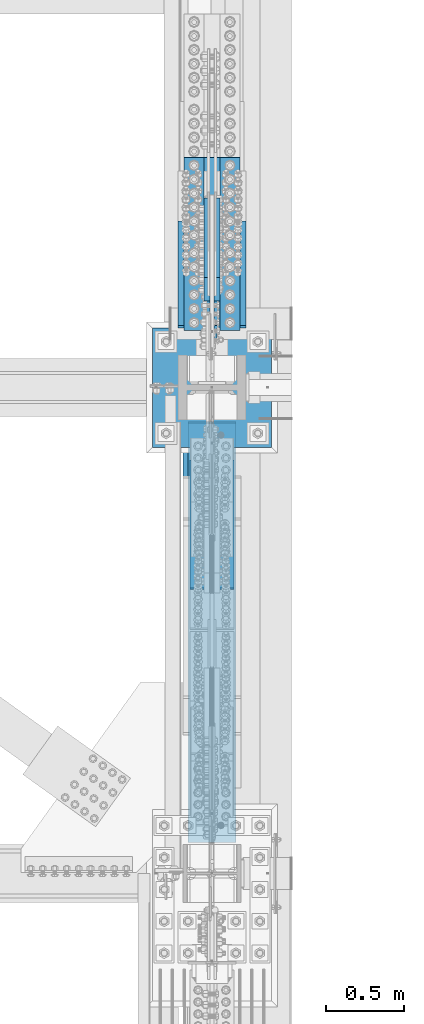
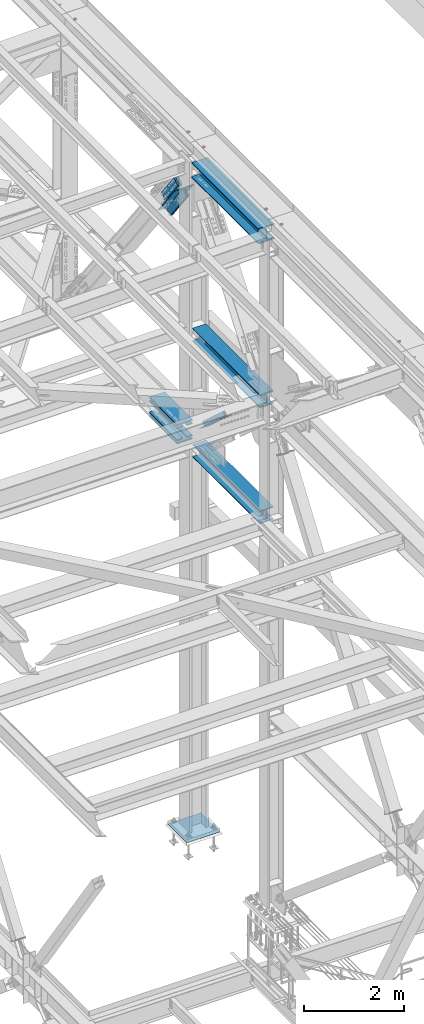
# One storey, part 1957 of 3843: 10 beams, 6 members, 7 elements without a shape of their own.
"""IFC2X3 building model written with IfcOpenShell, lengths in millimetres."""

from ifc_helpers import new_model, si_unit, frame, origin_with_axes, place, context, subcontext, project, spatial, faceted_brep, material, type_object, element, aggregate, save


model = new_model("IFC2X3")

# Units and contexts
model_context = context("Model", 3, precision=1e-05, world=origin_with_axes())
body_context = subcontext(model_context, "Body", "Model", "MODEL_VIEW")
ifc_project = project(units=[si_unit("LENGTHUNIT", "METRE", prefix="MILLI"), si_unit("AREAUNIT", "SQUARE_METRE"), si_unit("VOLUMEUNIT", "CUBIC_METRE"), si_unit("MASSUNIT", "GRAM", prefix="KILO"), si_unit("TIMEUNIT", "SECOND"), si_unit("PLANEANGLEUNIT", "RADIAN"), si_unit("SOLIDANGLEUNIT", "STERADIAN"), si_unit("THERMODYNAMICTEMPERATUREUNIT", "DEGREE_CELSIUS"), si_unit("LUMINOUSINTENSITYUNIT", "LUMEN")], contexts=[model_context])

# Site, building, storey
site_placement = place(None, origin_with_axes())
site = spatial("IfcSite", under=ifc_project, at=site_placement, CompositionType="ELEMENT")
building_placement = place(site_placement, origin_with_axes())
building = spatial("IfcBuilding", under=site, at=building_placement, Name="Undefined", CompositionType="ELEMENT")
storey_placement = place(building_placement, origin_with_axes())
storey = spatial("IfcBuildingStorey", under=building, at=storey_placement, Name="Undefined", CompositionType="ELEMENT", Elevation=0.0)

# Assembly, beams
assembly_1_placement = place(storey_placement, origin_with_axes())
assembly_1 = element("IfcElementAssembly", 1, at=assembly_1_placement, inside=storey, Name="COLUMN", AssemblyPlace="NOTDEFINED", PredefinedType="RIGID_FRAME")
ifc_material_1 = material(Name="STEEL/A572-50")
beam_type_1 = type_object("IfcBeamType", PredefinedType="NOTDEFINED")
beam_1_placement = place(assembly_1_placement, frame((85763.1, 29078.3813100748, 39333.7241634409), z_axis=(-1.0, 0.0, 0.0), x_axis=(0.0, 0.999988026952938, 0.00489345999977453)))
beam_1 = element("IfcBeam", 2, at=beam_1_placement, type_object=beam_type_1, material=ifc_material_1, Name="PLATE", context=body_context, shape_type="Brep", body=[
    faceted_brep([(8.73114913702011e-11, 15.8750000000073, -63.5), (8.73114913702011e-11, 15.8750000000073, 63.5), (1104.89999997285, 15.8750000015862, 63.5), (1104.89999997285, 15.8750000015862, -63.5), (-1.01863406598568e-10, -15.8750000000146, 63.5), (1104.89999997268, -15.8749999984284, 63.5), (-1.01863406598568e-10, -15.8750000000146, -63.5), (1104.89999997268, -15.8749999984284, -63.5)], [[[0, 1, 2, 3]], [[1, 4, 5, 2]], [[4, 6, 7, 5]], [[6, 0, 3, 7]], [[5, 7, 3, 2]], [[6, 4, 1, 0]]]),
])
beam_2_placement = place(assembly_1_placement, frame((85763.1, 29076.9677179651, 39622.5944270495), z_axis=(-1.0, 0.0, 0.0), x_axis=(0.0, 0.999988026952938, 0.00489345999977453)))
beam_2 = element("IfcBeam", 3, at=beam_2_placement, type_object=beam_type_1, material=ifc_material_1, Name="PLATE", context=body_context, shape_type="Brep", body=[
    faceted_brep([(8.73114913702011e-11, 15.8750000000073, -63.5), (8.73114913702011e-11, 15.8750000000073, 63.5), (1104.89999997285, 15.8750000015862, 63.5), (1104.89999997285, 15.8750000015862, -63.5), (-1.01863406598568e-10, -15.8750000000146, 63.5), (1104.89999997268, -15.8749999984284, 63.5), (-1.01863406598568e-10, -15.8750000000146, -63.5), (1104.89999997268, -15.8749999984284, -63.5)], [[[0, 1, 2, 3]], [[1, 4, 5, 2]], [[4, 6, 7, 5]], [[6, 0, 3, 7]], [[5, 7, 3, 2]], [[6, 4, 1, 0]]]),
])
beam_3_placement = place(assembly_1_placement, frame((85534.5, 29078.3813100748, 39333.7241634409), z_axis=(-1.0, 0.0, 0.0), x_axis=(0.0, 0.999988026952938, 0.00489345999977453)))
beam_3 = element("IfcBeam", 4, at=beam_3_placement, type_object=beam_type_1, material=ifc_material_1, Name="PLATE", context=body_context, shape_type="Brep", body=[
    faceted_brep([(8.73114913702011e-11, 15.8750000000073, -63.5), (8.73114913702011e-11, 15.8750000000073, 63.5), (1104.89999997285, 15.8750000015862, 63.5), (1104.89999997285, 15.8750000015862, -63.5), (-1.01863406598568e-10, -15.8750000000146, 63.5), (1104.89999997268, -15.8749999984284, 63.5), (-1.01863406598568e-10, -15.8750000000146, -63.5), (1104.89999997268, -15.8749999984284, -63.5)], [[[0, 1, 2, 3]], [[1, 4, 5, 2]], [[4, 6, 7, 5]], [[6, 0, 3, 7]], [[5, 7, 3, 2]], [[6, 4, 1, 0]]]),
])
beam_4_placement = place(assembly_1_placement, frame((85534.5, 29076.9677179651, 39622.5944270495), z_axis=(-1.0, 0.0, 0.0), x_axis=(0.0, 0.999988026952938, 0.00489345999977453)))
beam_4 = element("IfcBeam", 5, at=beam_4_placement, type_object=beam_type_1, material=ifc_material_1, Name="PLATE", context=body_context, shape_type="Brep", body=[
    faceted_brep([(8.73114913702011e-11, 15.8750000000073, -63.5), (8.73114913702011e-11, 15.8750000000073, 63.5), (1104.89999997285, 15.8750000015862, 63.5), (1104.89999997285, 15.8750000015862, -63.5), (-1.01863406598568e-10, -15.8750000000146, 63.5), (1104.89999997268, -15.8749999984284, 63.5), (-1.01863406598568e-10, -15.8750000000146, -63.5), (1104.89999997268, -15.8749999984284, -63.5)], [[[0, 1, 2, 3]], [[1, 4, 5, 2]], [[4, 6, 7, 5]], [[6, 0, 3, 7]], [[5, 7, 3, 2]], [[6, 4, 1, 0]]]),
])
beam_type_2 = type_object("IfcBeamType", PredefinedType="NOTDEFINED")
beam_5_placement = place(assembly_1_placement, frame((85648.8, 30183.6580881861, 39259.7461953867), z_axis=(-1.0, 0.0, 0.0), x_axis=(0.0, -0.999988026952938, -0.00489345999977453)))
beam_5 = element("IfcBeam", 6, at=beam_5_placement, type_object=beam_type_2, material=ifc_material_1, Name="PLATE", context=body_context, shape_type="Brep", body=[
    faceted_brep([(1.45519152283669e-11, 15.8750000000218, -177.800000000003), (1.45519152283669e-11, 15.8750000000218, 177.800000000003), (1104.89999996551, 15.8749999977663, 177.800000000003), (1104.89999996551, 15.8749999977663, -177.800000000003), (-4.36557456851006e-11, -15.8750000000146, 177.800000000003), (1104.89999996545, -15.8750000022774, 177.800000000003), (-4.36557456851006e-11, -15.8750000000146, -177.800000000003), (1104.89999996545, -15.8750000022774, -177.800000000003)], [[[0, 1, 2, 3]], [[1, 4, 5, 2]], [[4, 6, 7, 5]], [[6, 0, 3, 7]], [[5, 7, 3, 2]], [[6, 4, 1, 0]]]),
])
beam_6_placement = place(assembly_1_placement, frame((85648.8, 30181.4652221624, 39707.548624072), z_axis=(-1.0, 0.0, 0.0), x_axis=(0.0, -0.999988026952938, -0.00489345999977453)))
beam_6 = element("IfcBeam", 7, at=beam_6_placement, type_object=beam_type_2, material=ifc_material_1, Name="PLATE", context=body_context, shape_type="Brep", body=[
    faceted_brep([(1.45519152283669e-11, 15.8750000000218, -177.800000000003), (1.45519152283669e-11, 15.8750000000218, 177.800000000003), (1104.89999996551, 15.8749999977663, 177.800000000003), (1104.89999996551, 15.8749999977663, -177.800000000003), (-4.36557456851006e-11, -15.8750000000146, 177.800000000003), (1104.89999996545, -15.8750000022774, 177.800000000003), (-4.36557456851006e-11, -15.8750000000146, -177.800000000003), (1104.89999996545, -15.8750000022774, -177.800000000003)], [[[0, 1, 2, 3]], [[1, 4, 5, 2]], [[4, 6, 7, 5]], [[6, 0, 3, 7]], [[5, 7, 3, 2]], [[6, 4, 1, 0]]]),
])
aggregate(assembly_1, [beam_1, beam_2, beam_3, beam_4, beam_5, beam_6])

# Assembly, members
assembly_2_placement = place(storey_placement, origin_with_axes())
assembly_2 = element("IfcElementAssembly", 8, at=assembly_2_placement, inside=storey, Name="V. BRACE", AssemblyPlace="NOTDEFINED", PredefinedType="RIGID_FRAME")
member_type_1 = type_object("IfcMemberType", PredefinedType="NOTDEFINED")
member_1_placement = place(assembly_2_placement, frame((85680.55, 29341.3828673622, 45424.3500689701), z_axis=(0.0, 0.796057772587748, 0.60522063968658), x_axis=(0.0, 0.605220639686578, -0.79605777258775)))
member_1 = element("IfcMember", 9, at=member_1_placement, type_object=member_type_1, material=ifc_material_1, Name="PLATE", context=body_context, shape_type="Brep", body=[
    faceted_brep([(1.16415321826935e-10, 19.0500000000029, -95.2500000001601), (-1.16415321826935e-10, 19.0500000000029, 95.2500000001601), (838.200000012905, 19.0500000000029, 95.250000001266), (838.200000013152, 19.0500000000029, -95.249999999076), (-1.16415321826935e-10, -19.0500000000029, 95.2500000001601), (838.200000012905, -19.0500000000029, 95.250000001266), (1.16415321826935e-10, -19.0500000000029, -95.2500000001601), (838.200000013152, -19.0500000000029, -95.249999999076)], [[[0, 1, 2, 3]], [[1, 4, 5, 2]], [[4, 6, 7, 5]], [[6, 0, 3, 7]], [[5, 7, 3, 2]], [[6, 4, 1, 0]]]),
])
member_2_placement = place(assembly_2_placement, frame((85617.05, 29341.3828673622, 45424.3500689701), z_axis=(0.0, 0.796057772587748, 0.60522063968658), x_axis=(0.0, 0.605220639686578, -0.79605777258775)))
member_2 = element("IfcMember", 10, at=member_2_placement, type_object=member_type_1, material=ifc_material_1, Name="PLATE", context=body_context, shape_type="Brep", body=[
    faceted_brep([(1.16415321826935e-10, 19.0500000000029, -95.2500000001601), (-1.16415321826935e-10, 19.0500000000029, 95.2500000001601), (838.200000012905, 19.0500000000029, 95.250000001266), (838.200000013152, 19.0500000000029, -95.249999999076), (-1.16415321826935e-10, -19.0500000000029, 95.2500000001601), (838.200000012905, -19.0500000000029, 95.250000001266), (1.16415321826935e-10, -19.0500000000029, -95.2500000001601), (838.200000013152, -19.0500000000029, -95.249999999076)], [[[0, 1, 2, 3]], [[1, 4, 5, 2]], [[4, 6, 7, 5]], [[6, 0, 3, 7]], [[5, 7, 3, 2]], [[6, 4, 1, 0]]]),
])
member_type_2 = type_object("IfcMemberType", Name="L8X8X3/4", PredefinedType="NOTDEFINED")
member_3_placement = place(assembly_2_placement, frame((85763.1, 29696.8563105987, 44474.1546618168), z_axis=(0.0, -0.796057916025909, -0.605220451019698), x_axis=(0.0, -0.605220451019698, 0.796057916025909)))
member_3 = element("IfcMember", 11, at=member_3_placement, type_object=member_type_2, material=ifc_material_1, Name="ANGLE", ObjectType="L8X8X3/4", context=body_context, shape_type="Brep", body=[
    faceted_brep([(2.18278728425503e-10, 101.600000000345, -101.600000000006), (2.18278728425503e-10, 101.600000000345, 101.600000000006), (1104.90000001518, 101.600000000006, 101.599999998441), (1104.90000001537, 101.600000000006, -101.600000001323), (-8.73114913702011e-11, 82.5500000000029, 101.599999999882), (1104.90000001518, 82.5500000000029, 101.599999998441), (7.27595761418343e-11, 82.5500000000029, -82.549999999901), (1104.90000001535, 82.5500000000029, -82.550000001349), (7.27595761418343e-11, -101.600000000006, -82.549999999901), (1104.90000001535, -101.600000000006, -82.550000001349), (-2.25554686039686e-10, -101.600000000329, -101.600000000006), (1104.90000001537, -101.600000000006, -101.600000001323)], [[[0, 1, 2, 3]], [[1, 4, 5, 2]], [[4, 6, 7, 5]], [[6, 8, 9, 7]], [[8, 10, 11, 9]], [[10, 0, 3, 11]], [[5, 7, 9, 11, 3, 2]], [[10, 8, 6, 4, 1, 0]]]),
])
member_4_placement = place(assembly_2_placement, frame((85534.5, 29028.1482342624, 45353.7190532423), z_axis=(0.0, -0.796057916025909, -0.605220451019698), x_axis=(0.0, 0.605220639686578, -0.79605777258775)))
member_4 = element("IfcMember", 12, at=member_4_placement, type_object=member_type_2, material=ifc_material_1, Name="ANGLE", ObjectType="L8X8X3/4", context=body_context, shape_type="Brep", body=[
    faceted_brep([(2.18278728425503e-10, 101.600000000345, -101.600000000006), (2.18278728425503e-10, 101.600000000345, 101.600000000006), (1104.90000001518, 101.600000000006, 101.599999998441), (1104.90000001537, 101.600000000006, -101.600000001323), (-8.73114913702011e-11, 82.5500000000029, 101.599999999882), (1104.90000001518, 82.5500000000029, 101.599999998441), (7.27595761418343e-11, 82.5500000000029, -82.549999999901), (1104.90000001535, 82.5500000000029, -82.550000001349), (7.27595761418343e-11, -101.600000000006, -82.549999999901), (1104.90000001535, -101.600000000006, -82.550000001349), (-2.25554686039686e-10, -101.600000000329, -101.600000000006), (1104.90000001537, -101.600000000006, -101.600000001323)], [[[0, 1, 2, 3]], [[1, 4, 5, 2]], [[4, 6, 7, 5]], [[6, 8, 9, 7]], [[8, 10, 11, 9]], [[10, 0, 3, 11]], [[5, 7, 9, 11, 3, 2]], [[10, 8, 6, 4, 1, 0]]]),
])
aggregate(assembly_2, [member_1, member_3, member_4, member_2])

# Assembly, beam
assembly_3_placement = place(storey_placement, origin_with_axes())
assembly_3 = element("IfcElementAssembly", 13, at=assembly_3_placement, inside=storey, Name="BEAM", AssemblyPlace="NOTDEFINED", PredefinedType="RIGID_FRAME")
ifc_material_2 = material(Name="STEEL/A992")
beam_type_3 = type_object("IfcBeamType", Name="W14X120", PredefinedType="NOTDEFINED")
beam_7_placement = place(assembly_3_placement, frame((85648.8, 25615.9, 46272.45), z_axis=(0.0, 0.0, 1.0), x_axis=(0.0, 1.0, 0.0)))
beam_7 = element("IfcBeam", 14, at=beam_7_placement, type_object=beam_type_3, material=ifc_material_2, Name="BEAM", ObjectType="W14X120", context=body_context, shape_type="Brep", body=[
    faceted_brep([(2882.90000000001, -185.737500000003, 160.337500000001), (2882.90000000001, -7.14375000000291, 160.337500000001), (2882.90000000001, 7.14375000000291, 160.337500000001), (2882.90000000001, 185.737500000003, 160.337500000001), (2869.15142849347, 185.737500000003, 184.150000000001), (2869.15142849347, -185.737500000003, 184.150000000001), (209.240292719613, -7.14375000000291, -159.940499496464), (209.240292719613, 7.14375000000291, -159.940499496464), (209.011084125363, 7.14375000000291, -160.337500000001), (209.011084125363, 185.737500000003, -160.337500000001), (195.262500000004, 185.737500000003, -184.150000000001), (195.262500000004, -185.737500000003, -184.150000000001), (209.011084125363, -185.737500000003, -160.337500000001), (209.011084125363, -7.14375000000291, -160.337500000001), (215.819493164065, -7.14375000000291, -159.940499496464), (215.819493164065, 7.14375000000291, -159.940499496464), (269.126123406648, -7.14375000000291, -150.671698168706), (269.126123406648, 7.14375000000291, -150.671698168706), (274.09800579794, -7.14375000000291, -148.151780799373), (274.09800579794, 7.14375000000291, -148.151780799373), (276.808447986099, -7.14375000000291, -143.281144166889), (276.808447986099, 7.14375000000291, -143.281144166889), (276.32924081192, -7.14375000000291, -137.72777054851), (276.32924081192, 7.14375000000291, -137.72777054851), (272.824491995605, -7.14375000000291, -133.39345009478), (272.824491995605, 7.14375000000291, -133.39345009478), (267.494426344088, -7.14375000000291, -131.762500000004), (267.494426344088, 7.14375000000291, -131.762500000004), (198.437500000004, -7.14375000000291, -131.762500000004), (198.437500000004, 7.14375000000291, -131.762500000004), (198.437500000004, -7.14375000000291, 131.762500000004), (198.437500000004, 7.14375000000291, 131.762500000004), (272.337432196313, -7.14375000000291, 131.762500000004), (272.337432196313, 7.14375000000291, 131.762500000004), (277.667497835286, -7.14375000000291, 133.393450086303), (277.667497835286, 7.14375000000291, 133.393450086303), (281.172246652834, -7.14375000000291, 137.727770520425), (281.172246652834, 7.14375000000291, 137.727770520425), (281.65145384783, -7.14375000000291, 143.281144122484), (281.65145384783, 7.14375000000291, 143.281144122484), (278.941011693802, -7.14375000000291, 148.151780757398), (278.941011693802, 7.14375000000291, 148.151780757398), (273.969129333436, -7.14375000000291, 150.67169815574), (273.969129333436, 7.14375000000291, 150.67169815574), (220.662501525883, -7.14375000000291, 159.940499496464), (220.662501525883, 7.14375000000291, 159.940499496464), (195.262500000004, -7.14375000000291, 159.940499496464), (195.262500000004, 7.14375000000291, 159.940499496464), (195.262500000004, -7.14375000000291, 160.337500000001), (195.262500000004, 7.14375000000291, 160.337500000001), (209.011071506542, -185.737500000003, 184.150000000001), (209.011071506542, 185.737500000003, 184.150000000001), (195.262500000004, 185.737500000003, 160.337500000001), (195.262500000004, -185.737500000003, 160.337500000001), (2882.90000000001, -7.14375000000291, 159.940499496464), (2882.90000000001, 7.14375000000291, 159.940499496464), (2857.49999847413, -7.14375000000291, 159.940499496464), (2857.49999847413, 7.14375000000291, 159.940499496464), (2804.19337066658, -7.14375000000291, 150.67169815574), (2804.19337066658, 7.14375000000291, 150.67169815574), (2799.22148830621, -7.14375000000291, 148.151780757398), (2799.22148830621, 7.14375000000291, 148.151780757398), (2796.51104615218, -7.14375000000291, 143.281144122484), (2796.51104615218, 7.14375000000291, 143.281144122484), (2796.99025334718, -7.14375000000291, 137.727770520425), (2796.99025334718, 7.14375000000291, 137.727770520425), (2800.49500216473, -7.14375000000291, 133.393450086303), (2800.49500216473, 7.14375000000291, 133.393450086303), (2805.8250678037, -7.14375000000291, 131.762500000004), (2805.8250678037, 7.14375000000291, 131.762500000004), (2879.72500000001, -7.14375000000291, 131.762500000004), (2879.72500000001, 7.14375000000291, 131.762500000004), (2879.72500000001, -7.14375000000291, -131.762500000004), (2879.72500000001, 7.14375000000291, -131.762500000004), (2810.66807365592, -7.14375000000291, -131.762500000004), (2810.66807365592, 7.14375000000291, -131.762500000004), (2805.33800800441, -7.14375000000291, -133.39345009478), (2805.33800800441, 7.14375000000291, -133.39345009478), (2801.83325918809, -7.14375000000291, -137.72777054851), (2801.83325918809, 7.14375000000291, -137.72777054851), (2801.35405201391, -7.14375000000291, -143.281144166889), (2801.35405201391, 7.14375000000291, -143.281144166889), (2804.06449420207, -7.14375000000291, -148.151780799373), (2804.06449420207, 7.14375000000291, -148.151780799373), (2809.03637659337, -7.14375000000291, -150.671698168706), (2809.03637659337, 7.14375000000291, -150.671698168706), (2862.34300683595, -7.14375000000291, -159.940499496464), (2862.34300683595, 7.14375000000291, -159.940499496464), (2868.9222072804, -7.14375000000291, -159.940499496464), (2868.9222072804, 7.14375000000291, -159.940499496464), (2869.15141587465, 7.14375000000291, -160.337500000001), (2869.15141587465, 185.737500000003, -160.337500000001), (2882.90000000001, 185.737500000003, -184.150000000001), (2882.90000000001, -185.737500000003, -184.150000000001), (2869.15141587465, -185.737500000003, -160.337500000001), (2869.15141587465, -7.14375000000291, -160.337500000001)], [[[0, 1, 2, 3, 4, 5]], [[6, 7, 8, 9, 10, 11, 12, 13]], [[14, 15, 7, 6]], [[16, 17, 15, 14]], [[18, 19, 17, 16]], [[20, 21, 19, 18]], [[22, 23, 21, 20]], [[24, 25, 23, 22]], [[26, 27, 25, 24]], [[27, 26, 28, 29]], [[30, 31, 29, 28]], [[32, 33, 31, 30]], [[34, 35, 33, 32]], [[36, 37, 35, 34]], [[38, 39, 37, 36]], [[40, 41, 39, 38]], [[42, 43, 41, 40]], [[44, 45, 43, 42]], [[45, 44, 46, 47]], [[47, 46, 48, 49]], [[50, 51, 52, 49, 48, 53]], [[50, 53, 0, 5]], [[51, 50, 5, 4]], [[52, 51, 4, 3]], [[49, 52, 3, 2]], [[54, 55, 2, 1]], [[56, 57, 55, 54]], [[58, 59, 57, 56]], [[60, 61, 59, 58]], [[62, 63, 61, 60]], [[64, 65, 63, 62]], [[66, 67, 65, 64]], [[68, 69, 67, 66]], [[69, 68, 70, 71]], [[70, 72, 73, 71]], [[74, 75, 73, 72]], [[76, 77, 75, 74]], [[78, 79, 77, 76]], [[80, 81, 79, 78]], [[82, 83, 81, 80]], [[84, 85, 83, 82]], [[86, 87, 85, 84]], [[87, 86, 88, 89]], [[8, 7, 15, 17, 19, 21, 23, 25, 27, 29, 31, 33, 35, 37, 39, 41, 43, 45, 47, 49, 2, 55, 57, 59, 61, 63, 65, 67, 69, 71, 73, 75, 77, 79, 81, 83, 85, 87, 89, 90]], [[9, 8, 90, 91]], [[10, 9, 91, 92]], [[11, 10, 92, 93]], [[12, 11, 93, 94]], [[13, 12, 94, 95]], [[93, 92, 91, 90, 89, 88, 95, 94]], [[86, 84, 82, 80, 78, 76, 74, 72, 70, 68, 66, 64, 62, 60, 58, 56, 54, 1, 48, 46, 44, 42, 40, 38, 36, 34, 32, 30, 28, 26, 24, 22, 20, 18, 16, 14, 6, 13, 95, 88]], [[53, 48, 1, 0]]]),
])
aggregate(assembly_3, [beam_7])

assembly_4_placement = place(storey_placement, origin_with_axes())
assembly_4 = element("IfcElementAssembly", 15, at=assembly_4_placement, inside=storey, Name="BEAM", AssemblyPlace="NOTDEFINED", PredefinedType="RIGID_FRAME")
beam_type_4 = type_object("IfcBeamType", Name="W12X87", PredefinedType="NOTDEFINED")
beam_8_placement = place(assembly_4_placement, frame((85648.8000000244, 25615.9, 42246.55), z_axis=(0.0, 0.0, 1.0), x_axis=(0.0, 1.0, 0.0)))
beam_8 = element("IfcBeam", 16, at=beam_8_placement, type_object=beam_type_4, material=ifc_material_2, Name="BEAM", ObjectType="W12X87", context=body_context, shape_type="Brep", body=[
    faceted_brep([(207.17710064584, -153.987500000003, 158.75), (207.17710064584, 153.987500000003, 158.75), (195.262500000004, 153.987500000003, 138.112500000003), (195.262500000004, 6.35000000000582, 138.112500000003), (195.262500000004, -6.35000000000582, 138.112500000003), (195.262500000004, -153.987500000003, 138.112500000003), (2879.72500000001, 6.35000000000582, -138.112500000003), (2879.72500000001, 153.987500000003, -138.112500000003), (207.177115578957, 153.987500000003, -138.112500000003), (207.177115578957, 6.35000000000582, -138.112500000003), (2879.72500000001, -153.987500000003, -158.75), (2879.72500000001, -153.987500000003, -138.112500000003), (207.177115578957, -153.987500000003, -138.112500000003), (195.262500000004, -153.987500000003, -158.75), (2879.72500000001, 153.987500000003, -158.75), (195.262500000004, 153.987500000003, -158.75), (2879.72500000001, 6.35000000000582, 138.112500000003), (2879.72500000001, 153.987500000003, 138.112500000003), (2879.72500000001, 153.987500000003, 158.75), (2879.72500000001, -153.987500000003, 158.75), (2879.72500000001, -153.987500000003, 138.112500000003), (2879.72500000001, -6.35000000000582, 138.112500000003), (2879.72500000001, -6.35000000000582, -138.112500000003), (195.262500000004, 6.35000000000582, 137.715499999998), (195.262500000004, -6.35000000000582, 137.715499999998), (220.662500000006, 6.35000000000582, 137.715499999998), (220.662500000006, -6.35000000000582, 137.715499999998), (270.163859727083, 6.35000000000582, 131.692772740622), (270.163859727083, -6.35000000000582, 131.692772740622), (275.331081594562, 6.35000000000582, 129.36583947148), (275.331081594562, -6.35000000000582, 129.36583947148), (278.262008159629, 6.35000000000582, 124.515636410062), (278.262008159629, -6.35000000000582, 124.515636410062), (277.919158239056, 6.35000000000582, 118.859024862606), (277.919158239056, -6.35000000000582, 118.859024862606), (274.423892888255, 6.35000000000582, 114.398316354491), (274.423892888255, -6.35000000000582, 114.398316354491), (269.013456354503, 6.35000000000582, 112.712500000001), (269.013456354503, -6.35000000000582, 112.712500000001), (198.437500000004, 6.35000000000582, 112.712500000001), (198.437500000004, -6.35000000000582, 112.712500000001), (198.437500000004, 6.35000000000582, -112.712500000001), (198.437500000004, -6.35000000000582, -112.712500000001), (262.336456354504, 6.35000000000582, -112.712500000001), (262.336456354504, -6.35000000000582, -112.712500000001), (267.746892888255, 6.35000000000582, -114.398316354491), (267.746892888255, -6.35000000000582, -114.398316354491), (271.242158239056, 6.35000000000582, -118.859024862599), (271.242158239056, -6.35000000000582, -118.859024862599), (271.585008159629, 6.35000000000582, -124.515636410055), (271.585008159629, -6.35000000000582, -124.515636410055), (268.654081594563, 6.35000000000582, -129.36583947148), (268.654081594563, -6.35000000000582, -129.36583947148), (263.48685972708, 6.35000000000582, -131.692772740622), (263.48685972708, -6.35000000000582, -131.692772740622), (213.985500000006, 6.35000000000582, -137.715499999998), (213.985500000006, -6.35000000000582, -137.715499999998), (207.40630757586, 6.35000000000582, -137.715499999998), (207.40630757586, -6.35000000000582, -137.715499999998), (207.177115578957, -6.35000000000582, -138.112500000003)], [[[0, 1, 2, 3, 4, 5]], [[6, 7, 8, 9]], [[10, 11, 12, 13]], [[14, 10, 13, 15]], [[7, 14, 15, 8]], [[6, 16, 17, 18, 19, 20, 21, 22, 11, 10, 14, 7]], [[20, 19, 0, 5]], [[21, 20, 5, 4]], [[23, 24, 4, 3]], [[25, 26, 24, 23]], [[26, 25, 27, 28]], [[28, 27, 29, 30]], [[30, 29, 31, 32]], [[32, 31, 33, 34]], [[34, 33, 35, 36]], [[36, 35, 37, 38]], [[38, 37, 39, 40]], [[40, 39, 41, 42]], [[43, 44, 42, 41]], [[44, 43, 45, 46]], [[46, 45, 47, 48]], [[48, 47, 49, 50]], [[50, 49, 51, 52]], [[52, 51, 53, 54]], [[54, 53, 55, 56]], [[56, 55, 57, 58]], [[22, 21, 4, 24, 26, 28, 30, 32, 34, 36, 38, 40, 42, 44, 46, 48, 50, 52, 54, 56, 58, 59]], [[11, 22, 59, 12]], [[58, 57, 9, 8, 15, 13, 12, 59]], [[55, 53, 51, 49, 47, 45, 43, 41, 39, 37, 35, 33, 31, 29, 27, 25, 23, 3, 16, 6, 9, 57]], [[17, 16, 3, 2]], [[18, 17, 2, 1]], [[19, 18, 1, 0]]]),
])
aggregate(assembly_4, [beam_8])

assembly_5_placement = place(storey_placement, origin_with_axes())
assembly_5 = element("IfcElementAssembly", 17, at=assembly_5_placement, inside=storey, Name="BEAM", AssemblyPlace="NOTDEFINED", PredefinedType="RIGID_FRAME")
beam_9_placement = place(assembly_5_placement, frame((85648.8, 25615.9, 39427.15), z_axis=(0.0, 0.0, 1.0), x_axis=(0.0, 1.0, 0.0)))
beam_9 = element("IfcBeam", 18, at=beam_9_placement, type_object=beam_type_4, material=ifc_material_2, Name="BEAM", ObjectType="W12X87", context=body_context, shape_type="Brep", body=[
    faceted_brep([(198.4375, -153.987500000003, -158.75), (198.4375, -153.987500000003, -138.112500000003), (198.4375, -6.35000000000582, -138.112500000003), (198.4375, -6.35000000000582, 138.112500000003), (198.4375, -153.987500000003, 138.112500000003), (198.4375, -153.987500000003, 158.75), (198.4375, 153.987500000003, 158.75), (198.4375, 153.987500000003, 138.112500000003), (198.4375, 6.35000000000582, 138.112500000003), (198.4375, 6.35000000000582, 115.040000000001), (198.4375, 6.35000000000582, -115.040000000001), (198.4375, 6.35000000000582, -138.112500000003), (198.4375, 153.987500000003, -138.112500000003), (198.4375, 153.987500000003, -158.75), (2870.98539935417, 153.987500000003, 158.75), (2882.90000000001, 153.987500000003, 138.112500000003), (2882.90000000001, 6.35000000000582, 138.112500000003), (2882.90000000001, -6.35000000000582, 137.715500259401), (2882.90000000001, 6.35000000000582, 137.715500259401), (2882.90000000001, -6.35000000000582, 138.112500000003), (2843.21200180054, -6.35000000000582, 137.715500259401), (2843.21200180054, 6.35000000000582, 137.715500259401), (2829.79306614765, -6.35000000000582, 130.671038254979), (2829.79306614765, 6.35000000000582, 130.671038254979), (2826.12880078486, -6.35000000000582, 127.26264446976), (2826.12880078486, 6.35000000000582, 127.26264446976), (2824.69814091552, -6.35000000000582, 122.467104752235), (2824.69814091552, 6.35000000000582, 122.467104752235), (2825.89600729855, -6.35000000000582, 117.608184607539), (2825.89600729855, 6.35000000000582, 117.608184607539), (2829.39173971819, -6.35000000000582, 114.02714513633), (2829.39173971819, 6.35000000000582, 114.02714513633), (2834.22037275557, -6.35000000000582, 112.712500000001), (2834.22037275557, 6.35000000000582, 112.712500000001), (2879.72500000001, -6.35000000000582, 112.712500000001), (2879.72500000001, 6.35000000000582, 112.712500000001), (2879.72500000001, -6.35000000000582, -112.712500000001), (2879.72500000001, 6.35000000000582, -112.712500000001), (2834.54737038185, -6.35000000000582, -112.712500000001), (2834.54737038185, 6.35000000000582, -112.712500000001), (2829.71873739861, -6.35000000000582, -114.027145104497), (2829.71873739861, 6.35000000000582, -114.027145104497), (2826.22300498587, -6.35000000000582, -117.608184497782), (2826.22300498587, 6.35000000000582, -117.608184497782), (2825.02513853726, -6.35000000000582, -122.467104563912), (2825.02513853726, 6.35000000000582, -122.467104563912), (2826.45579827863, -6.35000000000582, -127.262644256385), (2826.45579827863, 6.35000000000582, -127.262644256385), (2830.12006349595, -6.35000000000582, -130.671038109045), (2830.12006349595, 6.35000000000582, -130.671038109045), (2843.53899835205, -6.35000000000582, -137.715500259401), (2843.53899835205, 6.35000000000582, -137.715500259401), (2870.75619257391, -6.35000000000582, -137.715500259401), (2870.75619257391, 6.35000000000582, -137.715500259401), (2870.98538442105, 6.35000000000582, -138.112500000003), (2870.98538442105, 153.987500000003, -138.112500000003), (2882.90000000001, 153.987500000003, -158.75), (2882.90000000001, -153.987500000003, -158.75), (2870.98538442105, -153.987500000003, -138.112500000003), (2870.98538442105, -6.35000000000582, -138.112500000003), (2882.90000000001, -153.987500000003, 138.112500000003), (2870.98539935417, -153.987500000003, 158.75)], [[[0, 1, 2, 3, 4, 5, 6, 7, 8, 9, 10, 11, 12, 13]], [[7, 6, 14, 15]], [[8, 7, 15, 16]], [[17, 18, 16, 19]], [[20, 21, 18, 17]], [[22, 23, 21, 20]], [[24, 25, 23, 22]], [[26, 27, 25, 24]], [[28, 29, 27, 26]], [[30, 31, 29, 28]], [[32, 33, 31, 30]], [[33, 32, 34, 35]], [[34, 36, 37, 35]], [[38, 39, 37, 36]], [[40, 41, 39, 38]], [[42, 43, 41, 40]], [[44, 45, 43, 42]], [[46, 47, 45, 44]], [[48, 49, 47, 46]], [[50, 51, 49, 48]], [[51, 50, 52, 53]], [[11, 10, 9, 8, 16, 18, 21, 23, 25, 27, 29, 31, 33, 35, 37, 39, 41, 43, 45, 47, 49, 51, 53, 54]], [[12, 11, 54, 55]], [[13, 12, 55, 56]], [[0, 13, 56, 57]], [[1, 0, 57, 58]], [[2, 1, 58, 59]], [[57, 56, 55, 54, 53, 52, 59, 58]], [[50, 48, 46, 44, 42, 40, 38, 36, 34, 32, 30, 28, 26, 24, 22, 20, 17, 19, 3, 2, 59, 52]], [[4, 3, 19, 60]], [[5, 4, 60, 61]], [[6, 5, 61, 14]], [[60, 19, 16, 15, 14, 61]]]),
])
aggregate(assembly_5, [beam_9])

# Assembly, members
assembly_6_placement = place(storey_placement, origin_with_axes())
assembly_6 = element("IfcElementAssembly", 19, at=assembly_6_placement, inside=storey, AssemblyPlace="NOTDEFINED", PredefinedType="RIGID_FRAME")
member_type_3 = type_object("IfcMemberType", Name="L5X5X1/2", PredefinedType="NOTDEFINED")
member_5_placement = place(assembly_6_placement, frame((85725.0000000244, 27469.330418704, 40892.899348702), z_axis=(0.0, 0.672974507774428, 0.73966567575207), x_axis=(0.0, 0.739665675752074, -0.672974507774424)))
member_5 = element("IfcMember", 20, at=member_5_placement, type_object=member_type_3, material=ifc_material_1, Name="ANGLE", ObjectType="L5X5X1/2", context=body_context, shape_type="Brep", body=[
    faceted_brep([(-1.01863406598568e-10, 63.5, -63.5000000002037), (1.01863406598568e-10, 63.5, 63.5000000002074), (1104.90000001364, 63.5, 63.500000003929), (1104.90000001345, 63.5, -63.499999996493), (1.01863406598568e-10, 50.8000000000029, 63.5000000002074), (1104.90000001364, 50.8000000000029, 63.500000003929), (0.0, 50.8000000000029, -50.8000000000029), (1104.90000001348, 50.8000000000029, -50.7999999964522), (-7.27595761418343e-11, -63.5, -50.8000000001666), (1104.90000001348, -63.5, -50.7999999964522), (-1.01863406598568e-10, -63.5, -63.5000000002037), (1104.90000001345, -63.5, -63.499999996493)], [[[0, 1, 2, 3]], [[1, 4, 5, 2]], [[4, 6, 7, 5]], [[6, 8, 9, 7]], [[8, 10, 11, 9]], [[10, 0, 3, 11]], [[5, 7, 9, 11, 3, 2]], [[10, 8, 6, 4, 1, 0]]]),
])
member_6_placement = place(assembly_6_placement, frame((85572.6000000244, 28286.5870238506, 40149.3298150642), z_axis=(0.0, 0.672974507774428, 0.73966567575207), x_axis=(0.0, -0.739665675752071, 0.672974507774427)))
member_6 = element("IfcMember", 21, at=member_6_placement, type_object=member_type_3, material=ifc_material_1, Name="ANGLE", ObjectType="L5X5X1/2", context=body_context, shape_type="Brep", body=[
    faceted_brep([(-1.01863406598568e-10, 63.5, -63.5000000002037), (1.01863406598568e-10, 63.5, 63.5000000002074), (1104.90000001364, 63.5, 63.500000003929), (1104.90000001345, 63.5, -63.499999996493), (1.01863406598568e-10, 50.8000000000029, 63.5000000002074), (1104.90000001364, 50.8000000000029, 63.500000003929), (0.0, 50.8000000000029, -50.8000000000029), (1104.90000001348, 50.8000000000029, -50.7999999964522), (-7.27595761418343e-11, -63.5, -50.8000000001666), (1104.90000001348, -63.5, -50.7999999964522), (-1.01863406598568e-10, -63.5, -63.5000000002037), (1104.90000001345, -63.5, -63.499999996493)], [[[0, 1, 2, 3]], [[1, 4, 5, 2]], [[4, 6, 7, 5]], [[6, 8, 9, 7]], [[8, 10, 11, 9]], [[10, 0, 3, 11]], [[5, 7, 9, 11, 3, 2]], [[10, 8, 6, 4, 1, 0]]]),
])
aggregate(assembly_6, [member_5, member_6])

# Assembly, beam
assembly_7_placement = place(storey_placement, origin_with_axes())
assembly_7 = element("IfcElementAssembly", 22, at=assembly_7_placement, inside=storey, Name="TEMPLATE", AssemblyPlace="NOTDEFINED", PredefinedType="RIGID_FRAME")
ifc_material_3 = material(Name="STEEL/A36")
beam_type_5 = type_object("IfcBeamType", PredefinedType="NOTDEFINED")
beam_10_placement = place(assembly_7_placement, frame((86029.8, 28714.7, 30064.075), z_axis=(0.0, -1.0, 0.0), x_axis=(-1.0, 0.0, 0.0)))
beam_10 = element("IfcBeam", 23, at=beam_10_placement, type_object=beam_type_5, material=ifc_material_3, Name="TEMPLATE", context=body_context, shape_type="Brep", body=[
    faceted_brep([(0.0, 3.17499999999927, -381.0), (0.0, 3.17500000000291, 381.0), (762.0, 3.17499999999927, 381.0), (762.0, 3.17499999999927, -381.0), (0.0, -3.17500000000291, 381.0), (762.0, -3.17499999999927, 381.0), (0.0, -3.17499999999927, -381.0), (762.0, -3.17499999999927, -381.0)], [[[0, 1, 2, 3]], [[1, 4, 5, 2]], [[4, 6, 7, 5]], [[6, 0, 3, 7]], [[5, 7, 3, 2]], [[6, 4, 1, 0]]]),
])
aggregate(assembly_7, [beam_10])

save(model, "model.ifc")
